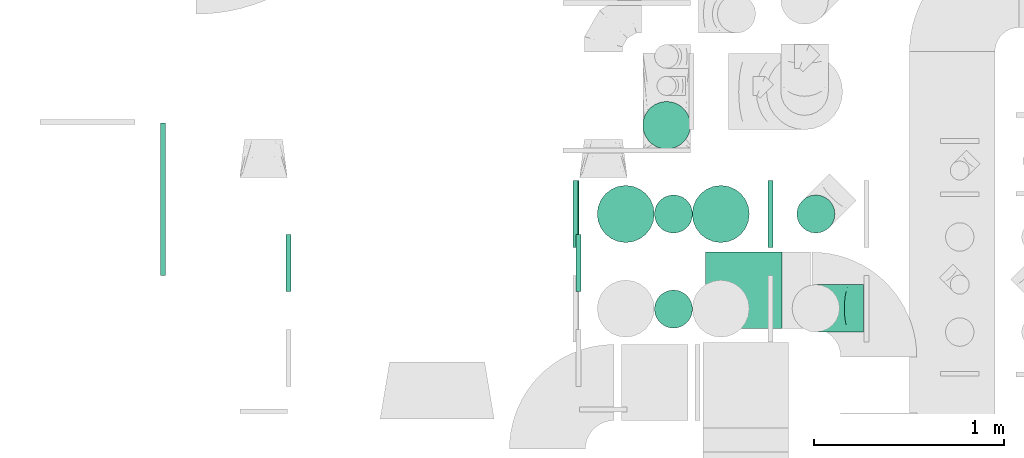
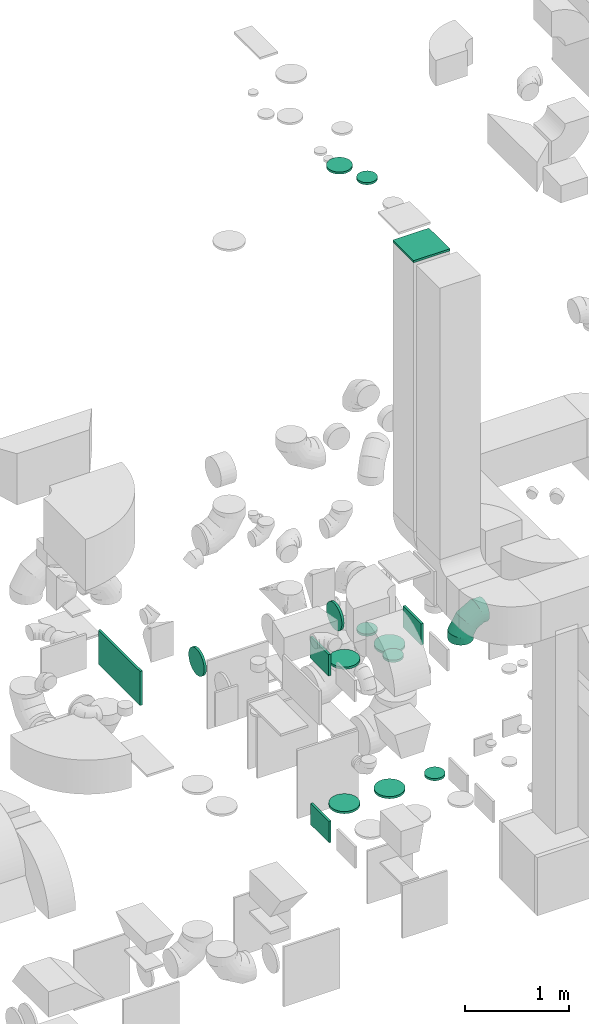
# One storey, part 24 of 59: 17 flow fittings.
"""IFC2X3 building model written with IfcOpenShell, lengths in millimetres."""

import ifcopenshell
import ifcopenshell.guid

model = None  # the IFC model being written
_history = None  # IfcOwnerHistory: only IFC2X3 demands one
_inside = {}  # id of a spatial element -> (the spatial element, [elements in it])
_under = {}  # id of a project, library or spatial element -> (it, [spatial elements below it])
_declared = {}  # id of a project -> (the project, [libraries it declares])
_typed = {}  # id of a type object -> (the type object, [elements of that type])
_made_of = {}  # id of a material, layer set ... -> (it, [elements and type objects made of it])


def new_model(schema):
    """Start an empty IFC model of exactly this schema.

    Asked for "IFC4X3", IfcOpenShell would pick the latest addendum, in which some entities
    have other attributes; the version numbers below select the first issue.
    IFC2X3 requires an IfcOwnerHistory on every rooted entity: one is made here for all.
    """
    global model, _history
    if schema == "IFC4X3":
        model = ifcopenshell.file(schema_version=(4, 3, 0, 0))
    else:
        model = ifcopenshell.file(schema=schema)
    _inside.clear()
    _under.clear()
    _declared.clear()
    _typed.clear()
    _made_of.clear()
    _history = None
    if model.schema == "IFC2X3":
        org = make("IfcOrganization", Name="unknown")
        user = make(
            "IfcPersonAndOrganization",
            ThePerson=make("IfcPerson", FamilyName="unknown"),
            TheOrganization=org,
        )
        app = make(
            "IfcApplication",
            ApplicationDeveloper=org,
            Version="unknown",
            ApplicationFullName="unknown",
            ApplicationIdentifier="unknown",
        )
        _history = make(
            "IfcOwnerHistory",
            OwningUser=user,
            OwningApplication=app,
            ChangeAction="ADDED",
            CreationDate=0,
        )
    return model


def make(cls, **values):
    """One entity of the class cls with the attributes given. An attribute that is None is left unset."""
    return model.create_entity(
        cls, **{name: value for name, value in values.items() if value is not None}
    )


def entity(cls, *values):
    """Any entity or typed value of the class cls, its attributes in the order of the schema. None: left unset."""
    e = model.create_entity(cls)
    for i, value in enumerate(values):
        if value is not None:
            e[i] = value
    return e


def rooted(cls, **values):
    """An entity with a GlobalId (a new one), such as an element, a storey or a relation."""
    return make(cls, GlobalId=ifcopenshell.guid.new(), OwnerHistory=_history, **values)


def si_unit(unit_type, name, prefix=None):
    """IfcSIUnit, for example si_unit("LENGTHUNIT", "METRE", prefix="MILLI")."""
    return make("IfcSIUnit", UnitType=unit_type, Prefix=prefix, Name=name)


def converted_unit(unit_type, name, factor, base, dimensions=None, offset=None):
    """IfcConversionBasedUnit, such as the inch: factor (a typed value) times the base unit."""
    return make(
        "IfcConversionBasedUnit"
        if offset is None
        else "IfcConversionBasedUnitWithOffset",
        ConversionOffset=offset,
        Dimensions=None
        if dimensions is None
        else entity("IfcDimensionalExponents", *dimensions),
        UnitType=unit_type,
        Name=name,
        ConversionFactor=make(
            "IfcMeasureWithUnit", ValueComponent=factor, UnitComponent=base
        ),
    )


def derived_unit(unit_type, elements):
    """IfcDerivedUnit: a product of units, each with its exponent."""
    return make(
        "IfcDerivedUnit",
        Elements=[
            make("IfcDerivedUnitElement", Unit=unit, Exponent=power)
            for unit, power in elements
        ],
        UnitType=unit_type,
    )


def assignment(units):
    """IfcUnitAssignment: the units of a project."""
    return None if units is None else make("IfcUnitAssignment", Units=units)


def point(xyz):
    """IfcCartesianPoint."""
    return None if xyz is None else make("IfcCartesianPoint", Coordinates=xyz)


def direction(xyz):
    """IfcDirection."""
    return None if xyz is None else make("IfcDirection", DirectionRatios=xyz)


def frame(location, z_axis=None, x_axis=None):
    """IfcAxis2Placement3D, a coordinate frame: its origin and axes. An axis left out is left unset."""
    return make(
        "IfcAxis2Placement3D",
        Location=point(location),
        Axis=direction(z_axis),
        RefDirection=direction(x_axis),
    )


def frame_2d(location, x_axis=None):
    """IfcAxis2Placement2D, a coordinate frame in the plane: its origin and x axis."""
    return make(
        "IfcAxis2Placement2D", Location=point(location), RefDirection=direction(x_axis)
    )


def origin():
    """The frame at (0, 0, 0) with its axes left unset."""
    return frame((0.0, 0.0, 0.0))


def origin_2d_with_axis():
    """The frame at (0, 0) in the plane with the x axis (1, 0) written out."""
    return frame_2d((0.0, 0.0), x_axis=(1.0, 0.0))


def place(relative_to, where):
    """IfcLocalPlacement: puts the frame where relative to a parent placement (None: the world)."""
    return make(
        "IfcLocalPlacement", PlacementRelTo=relative_to, RelativePlacement=where
    )


def context(
    kind, dimensions, precision=None, world=None, true_north=None, identifier=None
):
    """IfcGeometricRepresentationContext, for example the 3D "Model" context."""
    return make(
        "IfcGeometricRepresentationContext",
        ContextIdentifier=identifier,
        ContextType=kind,
        CoordinateSpaceDimension=dimensions,
        Precision=precision,
        WorldCoordinateSystem=world,
        TrueNorth=true_north,
    )


def subcontext(parent, identifier, kind, view, scale=None):
    """IfcGeometricRepresentationSubContext, for example "Body" below "Model"."""
    return make(
        "IfcGeometricRepresentationSubContext",
        ContextIdentifier=identifier,
        ContextType=kind,
        ParentContext=parent,
        TargetScale=scale,
        TargetView=view,
    )


def project(units=None, contexts=None):
    """IfcProject with its units and contexts."""
    return rooted(
        "IfcProject",
        Name="project",
        RepresentationContexts=contexts,
        UnitsInContext=assignment(units),
    )


def spatial(cls, under=None, at=None, **own):
    """A site, building, storey or space (cls), placed at a placement, below another one or the project."""
    s = rooted(cls, ObjectPlacement=at, **own)
    if under is not None:
        _under.setdefault(under.id(), (under, []))[1].append(s)
    return s


def profile(cls, at=None, kind="AREA", **sizes):
    """A parametric profile (cls). Its sizes go by their IFC names, for example OverallWidth=200.0."""
    return make(cls, ProfileType=kind, Position=at, **sizes)


def rectangle(**sizes):
    """IfcRectangleProfileDef."""
    return profile("IfcRectangleProfileDef", **sizes)


def circle(**sizes):
    """IfcCircleProfileDef."""
    return profile("IfcCircleProfileDef", **sizes)


def extrude(swept, where, along, depth):
    """IfcExtrudedAreaSolid: the profile swept, set in the frame where, extruded along a direction by depth."""
    return make(
        "IfcExtrudedAreaSolid",
        SweptArea=swept,
        Position=where,
        ExtrudedDirection=direction(along),
        Depth=depth,
    )


def faces_of(points, faces, orient=None, outer=None):
    """IfcFace entities. A face is a list of loops; a loop is a list of indices into points, from 0.

    orient and outer hold one flag for each loop. By default every Orientation is true, the
    first loop of a face is its IfcFaceOuterBound and the others are IfcFaceBound.
    """
    made = []
    for i, loops in enumerate(faces):
        bounds = []
        for j, loop in enumerate(loops):
            is_outer = j == 0 if outer is None else outer[i][j]
            bounds.append(
                make(
                    "IfcFaceOuterBound" if is_outer else "IfcFaceBound",
                    Bound=make("IfcPolyLoop", Polygon=[points[k] for k in loop]),
                    Orientation=True if orient is None else orient[i][j],
                )
            )
        made.append(make("IfcFace", Bounds=bounds))
    return made


def faceted_brep(points, faces, orient=None, outer=None, voids=None):
    """IfcFacetedBrep: a solid bounded by flat faces; with voids (closed shells), ...WithVoids."""
    shared = [point(p) for p in points]
    hull = make("IfcClosedShell", CfsFaces=faces_of(shared, faces, orient, outer))
    if voids is None:
        return make("IfcFacetedBrep", Outer=hull)
    return make(
        "IfcFacetedBrepWithVoids",
        Outer=hull,
        Voids=[
            make(cls, CfsFaces=faces_of(shared, fs, o, b)) for cls, fs, o, b in voids
        ],
    )


def shape(context_of_items, identifier, shape_type, items):
    """IfcShapeRepresentation: the items that make up one representation, for example the "Body"."""
    return make(
        "IfcShapeRepresentation",
        ContextOfItems=context_of_items,
        RepresentationIdentifier=identifier,
        RepresentationType=shape_type,
        Items=items,
    )


def source(mapping_origin, context_of_items, identifier, shape_type, items):
    """IfcRepresentationMap: a shape defined once, which mapped items show again and again."""
    return make(
        "IfcRepresentationMap",
        MappingOrigin=mapping_origin,
        MappedRepresentation=shape(context_of_items, identifier, shape_type, items),
    )


def transform(
    local_origin,
    x_axis=None,
    y_axis=None,
    z_axis=None,
    scale=None,
    scale2=None,
    scale3=None,
    uniform=True,
):
    """IfcCartesianTransformationOperator3D, or its non-uniform kind. x_axis, y_axis, z_axis: its Axis1, 2, 3."""
    if uniform:
        return make(
            "IfcCartesianTransformationOperator3D",
            Axis1=direction(x_axis),
            Axis2=direction(y_axis),
            LocalOrigin=point(local_origin),
            Scale=scale,
            Axis3=direction(z_axis),
        )
    return make(
        "IfcCartesianTransformationOperator3DnonUniform",
        Axis1=direction(x_axis),
        Axis2=direction(y_axis),
        LocalOrigin=point(local_origin),
        Scale=scale,
        Axis3=direction(z_axis),
        Scale2=scale2,
        Scale3=scale3,
    )


def mapped(mapping_source, mapping_target):
    """IfcMappedItem: shows the shape of a source again, moved by a transform."""
    return make(
        "IfcMappedItem", MappingSource=mapping_source, MappingTarget=mapping_target
    )


def material(Name=None, Category=None):
    """IfcMaterial."""
    return make("IfcMaterial", Name=Name, Category=Category)


def made_of(thing, what):
    """Note that an element or type object is made of a material, layer set ...; save() writes the relation."""
    if what is not None:
        _made_of.setdefault(what.id(), (what, []))[1].append(thing)
    return thing


def type_object(cls, material=None, **own):
    """A type object (cls), such as IfcWallType, which elements share."""
    return made_of(rooted(cls, **own), material)


def type_shapes(of_type, sources):
    """Give a type object the sources (RepresentationMaps) that its elements show as mapped items."""
    of_type.RepresentationMaps = sources


def element(
    cls,
    number,
    at=None,
    inside=None,
    cuts=None,
    type_object=None,
    material=None,
    context=None,
    identifier="Body",
    shape_type=None,
    held_by="IfcProductDefinitionShape",
    body=None,
    shapes=None,
    **own,
):
    """One element of the class cls, such as IfcWall. Its Tag is "e" and its number.

    at: its placement. inside: the storey or other place that contains it. cuts: it is an
    opening in that element (IfcRelVoidsElement). A single representation is given by context,
    identifier, shape_type and body (its items); several are given by shapes. held_by: the class
    of the entity that holds the representations. save() writes the other relations.
    """
    e = rooted(cls, Tag="e%d" % number, ObjectPlacement=at, **own)
    if body is not None:
        shapes = [shape(context, identifier, shape_type, body)]
    if shapes is not None:
        e.Representation = make(held_by, Representations=shapes)
    if inside is not None:
        _inside.setdefault(inside.id(), (inside, []))[1].append(e)
    if cuts is not None:
        rooted(
            "IfcRelVoidsElement", RelatingBuildingElement=cuts, RelatedOpeningElement=e
        )
    if type_object is not None:
        _typed.setdefault(type_object.id(), (type_object, []))[1].append(e)
    return made_of(e, material)


def aggregate(whole, parts):
    """IfcRelAggregates: a whole, such as a stair, and the parts it consists of."""
    return rooted("IfcRelAggregates", RelatingObject=whole, RelatedObjects=parts)


def save(model, path):
    """Write the relations noted so far, then the file.

    IfcRelAggregates (storeys below a building ...), IfcRelContainedInSpatialStructure (elements
    in a storey), IfcRelDefinesByType, IfcRelAssociatesMaterial and IfcRelDeclares: one each for
    every whole, place, type object, material and project.
    """
    for whole, parts in _under.values():
        aggregate(whole, parts)
    for where, things in _inside.values():
        rooted(
            "IfcRelContainedInSpatialStructure",
            RelatedElements=things,
            RelatingStructure=where,
        )
    for kind, things in _typed.values():
        rooted("IfcRelDefinesByType", RelatedObjects=things, RelatingType=kind)
    for what, things in _made_of.values():
        rooted("IfcRelAssociatesMaterial", RelatedObjects=things, RelatingMaterial=what)
    for by, libraries in _declared.values():
        rooted("IfcRelDeclares", RelatingContext=by, RelatedDefinitions=libraries)
    model.write(path)


model = new_model("IFC2X3")

# Units and contexts
model_context = context("Model", 3, precision=0.01, world=origin(), true_north=direction((6.12303176911189e-17, 1.0)))
body_context = subcontext(model_context, "Body", "Model", "MODEL_VIEW")
ifc_project = project(units=[si_unit("LENGTHUNIT", "METRE", prefix="MILLI"), si_unit("AREAUNIT", "SQUARE_METRE"), si_unit("VOLUMEUNIT", "CUBIC_METRE"), converted_unit("PLANEANGLEUNIT", "DEGREE", entity("IfcRatioMeasure", 0.0174532925199433), si_unit("PLANEANGLEUNIT", "RADIAN"), dimensions=[0, 0, 0, 0, 0, 0, 0]), si_unit("MASSUNIT", "GRAM", prefix="KILO"), derived_unit("MASSDENSITYUNIT", [(si_unit("MASSUNIT", "GRAM", prefix="KILO"), 1), (si_unit("LENGTHUNIT", "METRE"), -3)]), derived_unit("MOMENTOFINERTIAUNIT", [(si_unit("LENGTHUNIT", "METRE"), 4)]), si_unit("TIMEUNIT", "SECOND"), si_unit("FREQUENCYUNIT", "HERTZ"), si_unit("THERMODYNAMICTEMPERATUREUNIT", "DEGREE_CELSIUS"), derived_unit("THERMALTRANSMITTANCEUNIT", [(si_unit("MASSUNIT", "GRAM", prefix="KILO"), 1), (si_unit("THERMODYNAMICTEMPERATUREUNIT", "KELVIN"), -1), (si_unit("TIMEUNIT", "SECOND"), -3)]), derived_unit("VOLUMETRICFLOWRATEUNIT", [(si_unit("LENGTHUNIT", "METRE"), 3), (si_unit("TIMEUNIT", "SECOND"), -1)]), derived_unit("MASSFLOWRATEUNIT", [(si_unit("MASSUNIT", "GRAM", prefix="KILO"), 1), (si_unit("TIMEUNIT", "SECOND"), -1)]), derived_unit("ROTATIONALFREQUENCYUNIT", [(si_unit("TIMEUNIT", "SECOND"), -1)]), si_unit("ELECTRICCURRENTUNIT", "AMPERE"), si_unit("ELECTRICVOLTAGEUNIT", "VOLT"), si_unit("POWERUNIT", "WATT"), si_unit("FORCEUNIT", "NEWTON", prefix="KILO"), si_unit("ILLUMINANCEUNIT", "LUX"), si_unit("LUMINOUSFLUXUNIT", "LUMEN"), si_unit("LUMINOUSINTENSITYUNIT", "CANDELA"), derived_unit("USERDEFINED", [(si_unit("MASSUNIT", "GRAM", prefix="KILO"), -1), (si_unit("LENGTHUNIT", "METRE"), -2), (si_unit("TIMEUNIT", "SECOND"), 3), (si_unit("LUMINOUSFLUXUNIT", "LUMEN"), 1)]), derived_unit("LINEARVELOCITYUNIT", [(si_unit("LENGTHUNIT", "METRE"), 1), (si_unit("TIMEUNIT", "SECOND"), -1)]), si_unit("PRESSUREUNIT", "PASCAL"), derived_unit("USERDEFINED", [(si_unit("LENGTHUNIT", "METRE"), -2), (si_unit("MASSUNIT", "GRAM", prefix="KILO"), 1), (si_unit("TIMEUNIT", "SECOND"), -2)]), derived_unit("LINEARFORCEUNIT", [(si_unit("MASSUNIT", "GRAM", prefix="KILO"), 1), (si_unit("LENGTHUNIT", "METRE"), 1), (si_unit("TIMEUNIT", "SECOND"), -2), (si_unit("LENGTHUNIT", "METRE"), -1)]), derived_unit("PLANARFORCEUNIT", [(si_unit("MASSUNIT", "GRAM", prefix="KILO"), 1), (si_unit("LENGTHUNIT", "METRE"), 1), (si_unit("TIMEUNIT", "SECOND"), -2), (si_unit("LENGTHUNIT", "METRE"), -2)])], contexts=[model_context])

# Site, building, storey
site_placement = place(None, origin())
site = spatial("IfcSite", under=ifc_project, at=site_placement, CompositionType="ELEMENT")
building_placement = place(site_placement, origin())
building = spatial("IfcBuilding", under=site, at=building_placement, CompositionType="ELEMENT")
storey_placement = place(building_placement, frame((0.0, 0.0, 28200.0)))
storey = spatial("IfcBuildingStorey", under=building, at=storey_placement, CompositionType="ELEMENT", Elevation=28200.0)

# Flow fittings
ifc_material = material()
duct_fitting_type_1 = type_object("IfcDuctFittingType", PredefinedType="NOTDEFINED", material=ifc_material)
shared_shape_1 = source(origin(), body_context, "Body", "SweptSolid", [
    extrude(circle(Radius=99.9999999999994, at=origin_2d_with_axis()), frame((0.0, 0.0, 0.0), z_axis=(1.0, 0.0, 0.0), x_axis=(0.0, 1.0, 0.0)), (0.0, 0.0, 1.0), 25.0000000000018),
])
type_shapes(duct_fitting_type_1, [shared_shape_1])
flow_fitting_1_placement = place(storey_placement, frame((55631.15, 10234.06, 7677.46), z_axis=(-1.0, 0.0, 0.0), x_axis=(0.0, 0.0, 1.0)))
element("IfcFlowFitting", 1, at=flow_fitting_1_placement, inside=storey, type_object=duct_fitting_type_1, material=ifc_material, context=body_context, shape_type="MappedRepresentation", body=[
    mapped(shared_shape_1, transform((0.0, 0.0, 0.0), scale=1.0)),
])
duct_fitting_type_2 = type_object("IfcDuctFittingType", PredefinedType="NOTDEFINED", material=ifc_material)
shared_shape_2 = source(origin(), body_context, "Body", "SweptSolid", [
    extrude(rectangle(XDim=24.9999999999999, YDim=400.0, at=origin_2d_with_axis()), frame((12.5, 0.0, -200.0)), (0.0, 0.0, 1.0), 400.0),
])
type_shapes(duct_fitting_type_2, [shared_shape_2])
flow_fitting_2_placement = place(storey_placement, frame((56000.5, 9833.0, 7000.0), z_axis=(1.0, 0.0, 0.0), x_axis=(0.0, 0.0, 1.0)))
element("IfcFlowFitting", 2, at=flow_fitting_2_placement, inside=storey, type_object=duct_fitting_type_2, material=ifc_material, context=body_context, shape_type="MappedRepresentation", body=[
    mapped(shared_shape_2, transform((0.0, 0.0, 0.0), scale=1.0)),
])
duct_fitting_type_3 = type_object("IfcDuctFittingType", PredefinedType="NOTDEFINED", material=ifc_material)
shared_shape_3 = source(origin(), body_context, "Body", "SweptSolid", [
    extrude(circle(Radius=124.999999999999, at=origin_2d_with_axis()), frame((0.0, 0.0, 0.0), z_axis=(1.0, 0.0, 0.0), x_axis=(0.0, 1.0, 0.0)), (0.0, 0.0, 1.0), 25.0000000000018),
])
type_shapes(duct_fitting_type_3, [shared_shape_3])
flow_fitting_3_placement = place(storey_placement, frame((55595.02, 10700.6, 7548.56), z_axis=(0.0, 1.0, 0.0), x_axis=(0.0, 0.0, 1.0)))
element("IfcFlowFitting", 3, at=flow_fitting_3_placement, inside=storey, type_object=duct_fitting_type_3, material=ifc_material, context=body_context, shape_type="MappedRepresentation", body=[
    mapped(shared_shape_3, transform((0.0, 0.0, 0.0), scale=1.0)),
])
duct_fitting_type_4 = type_object("IfcDuctFittingType", PredefinedType="NOTDEFINED", material=ifc_material)
shared_shape_4 = source(origin(), body_context, "Body", "SweptSolid", [
    extrude(rectangle(XDim=24.9999999999999, YDim=350.0, at=origin_2d_with_axis()), frame((12.5, 0.0, -125.0)), (0.0, 0.0, 1.0), 250.0),
])
type_shapes(duct_fitting_type_4, [shared_shape_4])
for number, where, z_axis, x_axis in (
    (4, (55128.85, 10234.06, 2277.46), (0.0, 0.0, 1.0), (-1.0, 0.0, 0.0)),
    (5, (55133.85, 10234.06, 325.0), (0.0, 0.0, 1.0), (-1.0, 0.0, 0.0)),
):
    element("IfcFlowFitting", number, at=place(storey_placement, frame(where, z_axis=z_axis, x_axis=x_axis)), inside=storey, type_object=duct_fitting_type_4, material=ifc_material, context=body_context, shape_type="MappedRepresentation", body=[
        mapped(shared_shape_4, transform((0.0, 0.0, 0.0), scale=1.0)),
    ])
flow_fitting_4_placement = place(storey_placement, frame((56128.85, 10234.06, 2277.46)))
element("IfcFlowFitting", 6, at=flow_fitting_4_placement, inside=storey, type_object=duct_fitting_type_4, material=ifc_material, context=body_context, shape_type="MappedRepresentation", body=[
    mapped(shared_shape_4, transform((0.0, 0.0, 0.0), scale=1.0)),
])
duct_fitting_type_5 = type_object("IfcDuctFittingType", PredefinedType="NOTDEFINED", material=ifc_material)
shared_shape_5 = source(origin(), body_context, "Body", "SweptSolid", [
    extrude(rectangle(XDim=24.9999999999999, YDim=800.0, at=origin_2d_with_axis()), frame((12.5, 0.0, -200.0)), (0.0, 0.0, 1.0), 400.0),
])
type_shapes(duct_fitting_type_5, [shared_shape_5])
flow_fitting_5_placement = place(storey_placement, frame((52933.61, 10311.5, 2855.02)))
element("IfcFlowFitting", 7, at=flow_fitting_5_placement, inside=storey, type_object=duct_fitting_type_5, material=ifc_material, context=body_context, shape_type="MappedRepresentation", body=[
    mapped(shared_shape_5, transform((0.0, 0.0, 0.0), scale=1.0)),
])
duct_fitting_type_6 = type_object("IfcDuctFittingType", PredefinedType="NOTDEFINED", material=ifc_material)
shared_shape_6 = source(origin(), body_context, "Body", "Brep", [
    faceted_brep([(-250.0, 0.0, -125.0), (-250.0, -32.35, -120.74), (-250.0, -62.5, -108.25), (-250.0, -88.39, -88.39), (-250.0, -108.25, -62.5), (-250.0, -120.74, -32.35), (-250.0, -125.0, 0.0), (-250.0, -120.74, 32.35), (-250.0, -108.25, 62.5), (-250.0, -88.39, 88.39), (-250.0, -62.5, 108.25), (-250.0, -32.35, 120.74), (-250.0, 0.0, 125.0), (-250.0, 32.35, 120.74), (-250.0, 62.5, 108.25), (-250.0, 88.39, 88.39), (-250.0, 108.25, 62.5), (-250.0, 120.74, 32.35), (-250.0, 125.0, 0.0), (-250.0, 120.74, -32.35), (-250.0, 108.25, -62.5), (-250.0, 88.39, -88.39), (-250.0, 62.5, -108.25), (-250.0, 32.35, -120.74), (-191.68, 32.35, 120.74), (-199.76, 62.5, 108.25), (-183.01, 0.0, 125.0), (-206.7, 88.39, 88.39), (-215.37, 120.74, 32.35), (-216.51, 125.0, 0.0), (-212.02, 108.25, 62.5), (-212.02, 108.25, -62.5), (-206.7, 88.39, -88.39), (-215.37, 120.74, -32.35), (-191.68, 32.35, -120.74), (-183.01, 0.0, -125.0), (-199.76, 62.5, -108.25), (-174.34, -32.35, -120.74), (-166.27, -62.5, -108.25), (-159.33, -88.39, -88.39), (-154.01, -108.25, -62.5), (-150.66, -120.74, -32.35), (-149.52, -125.0, 0.0), (-150.66, -120.74, 32.35), (-154.01, -108.25, 62.5), (-159.33, -88.39, 88.39), (-166.27, -62.5, 108.25), (-174.34, -32.35, 120.74), (-90.67, 90.67, 120.74), (-112.74, 112.74, 108.25), (-66.99, 66.99, 125.0), (-131.69, 131.69, 88.39), (-146.23, 146.23, 62.5), (-155.38, 155.38, 32.35), (-158.49, 158.49, 0.0), (-155.38, 155.38, -32.35), (-146.23, 146.23, -62.5), (-131.69, 131.69, -88.39), (-90.67, 90.67, -120.74), (-66.99, 66.99, -125.0), (-112.74, 112.74, -108.25), (-43.3, 43.3, -120.74), (-21.23, 21.23, -108.25), (-2.28, 2.28, -88.39), (12.26, -12.26, -62.5), (21.4, -21.4, -32.35), (24.52, -24.52, 0.0), (21.4, -21.4, 32.35), (12.26, -12.26, 62.5), (-2.28, 2.28, 88.39), (-21.23, 21.23, 108.25), (-43.3, 43.3, 120.74), (-32.35, 191.68, 120.74), (-62.5, 199.76, 108.25), (0.0, 183.01, 125.0), (-88.39, 206.7, 88.39), (-108.25, 212.02, 62.5), (-120.74, 215.37, 32.35), (-125.0, 216.51, 0.0), (-120.74, 215.37, -32.35), (-108.25, 212.02, -62.5), (-88.39, 206.7, -88.39), (-32.35, 191.68, -120.74), (0.0, 183.01, -125.0), (-62.5, 199.76, -108.25), (32.35, 174.34, -120.74), (62.5, 166.27, -108.25), (88.39, 159.33, -88.39), (108.25, 154.01, -62.5), (120.74, 150.66, -32.35), (125.0, 149.52, 0.0), (120.74, 150.66, 32.35), (108.25, 154.01, 62.5), (88.39, 159.33, 88.39), (62.5, 166.27, 108.25), (32.35, 174.34, 120.74), (-32.35, 250.0, -120.74), (-62.5, 250.0, -108.25), (-88.39, 250.0, -88.39), (-108.25, 250.0, -62.5), (-120.74, 250.0, -32.35), (-125.0, 250.0, 0.0), (-120.74, 250.0, 32.35), (-108.25, 250.0, 62.5), (-88.39, 250.0, 88.39), (-62.5, 250.0, 108.25), (-32.35, 250.0, 120.74), (0.0, 250.0, 125.0), (32.35, 250.0, 120.74), (62.5, 250.0, 108.25), (88.39, 250.0, 88.39), (108.25, 250.0, 62.5), (120.74, 250.0, 32.35), (125.0, 250.0, 0.0), (120.74, 250.0, -32.35), (108.25, 250.0, -62.5), (88.39, 250.0, -88.39), (62.5, 250.0, -108.25), (32.35, 250.0, -120.74), (0.0, 250.0, -125.0)], [[[0, 1, 2, 3, 4, 5, 6, 7, 8, 9, 10, 11, 12, 13, 14, 15, 16, 17, 18, 19, 20, 21, 22, 23]], [[24, 25, 14, 13]], [[26, 24, 13, 12]], [[14, 25, 27, 15]], [[28, 29, 18, 17]], [[30, 28, 17, 16]], [[15, 27, 30, 16]], [[20, 31, 32, 21]], [[33, 31, 20, 19]], [[18, 29, 33, 19]], [[34, 35, 0, 23]], [[36, 34, 23, 22]], [[21, 32, 36, 22]], [[1, 0, 35, 37]], [[2, 1, 37, 38]], [[38, 39, 3, 2]], [[5, 4, 40, 41]], [[6, 5, 41, 42]], [[39, 40, 4, 3]], [[6, 42, 43, 7]], [[7, 43, 44, 8]], [[8, 44, 45, 9]], [[9, 45, 46, 10]], [[10, 46, 47, 11]], [[26, 12, 11, 47]], [[48, 49, 25, 24]], [[50, 48, 24, 26]], [[27, 25, 49, 51]], [[52, 53, 28, 30]], [[51, 52, 30, 27]], [[29, 28, 53, 54]], [[55, 56, 31, 33]], [[54, 55, 33, 29]], [[32, 31, 56, 57]], [[58, 59, 35, 34]], [[60, 58, 34, 36]], [[57, 60, 36, 32]], [[37, 35, 59, 61]], [[38, 37, 61, 62]], [[39, 38, 62, 63]], [[41, 40, 64, 65]], [[42, 41, 65, 66]], [[63, 64, 40, 39]], [[43, 42, 66, 67]], [[44, 43, 67, 68]], [[68, 69, 45, 44]], [[46, 45, 69, 70]], [[47, 46, 70, 71]], [[26, 47, 71, 50]], [[72, 73, 49, 48]], [[74, 72, 48, 50]], [[51, 49, 73, 75]], [[76, 77, 53, 52]], [[75, 76, 52, 51]], [[54, 53, 77, 78]], [[79, 80, 56, 55]], [[78, 79, 55, 54]], [[57, 56, 80, 81]], [[82, 83, 59, 58]], [[84, 82, 58, 60]], [[81, 84, 60, 57]], [[61, 59, 83, 85]], [[62, 61, 85, 86]], [[63, 62, 86, 87]], [[65, 64, 88, 89]], [[66, 65, 89, 90]], [[87, 88, 64, 63]], [[67, 66, 90, 91]], [[68, 67, 91, 92]], [[92, 93, 69, 68]], [[70, 69, 93, 94]], [[71, 70, 94, 95]], [[50, 71, 95, 74]], [[96, 97, 98, 99, 100, 101, 102, 103, 104, 105, 106, 107, 108, 109, 110, 111, 112, 113, 114, 115, 116, 117, 118, 119]], [[72, 74, 107, 106]], [[73, 72, 106, 105]], [[75, 73, 105, 104]], [[77, 76, 103, 102]], [[78, 77, 102, 101]], [[75, 104, 103, 76]], [[78, 101, 100, 79]], [[79, 100, 99, 80]], [[80, 99, 98, 81]], [[84, 97, 96, 82]], [[82, 96, 119, 83]], [[84, 81, 98, 97]], [[83, 119, 118, 85]], [[85, 118, 117, 86]], [[116, 87, 86, 117]], [[88, 115, 114, 89]], [[89, 114, 113, 90]], [[115, 88, 87, 116]], [[91, 90, 113, 112]], [[92, 91, 112, 111]], [[111, 110, 93, 92]], [[95, 94, 109, 108]], [[74, 95, 108, 107]], [[110, 109, 94, 93]]]),
])
type_shapes(duct_fitting_type_6, [shared_shape_6])
flow_fitting_6_placement = place(storey_placement, frame((56380.0, 9738.12, 2597.2), z_axis=(0.0, 1.0, 0.0), x_axis=(0.0, 0.0, 1.0)))
element("IfcFlowFitting", 8, at=flow_fitting_6_placement, inside=storey, type_object=duct_fitting_type_6, material=ifc_material, context=body_context, shape_type="MappedRepresentation", body=[
    mapped(shared_shape_6, transform((0.0, 0.0, 0.0), scale=1.0)),
])
duct_fitting_type_7 = type_object("IfcDuctFittingType", PredefinedType="NOTDEFINED", material=ifc_material)
shared_shape_7 = source(origin(), body_context, "Body", "Brep", [
    faceted_brep([(20.0, 25.88, -96.59), (20.0, 50.0, -86.6), (20.0, 70.71, -70.71), (20.0, 86.6, -50.0), (20.0, 96.59, -25.88), (20.0, 100.0, 0.0), (20.0, 96.59, 25.88), (20.0, 86.6, 50.0), (20.0, 70.71, 70.71), (20.0, 50.0, 86.6), (20.0, 25.88, 96.59), (20.0, 0.0, 100.0), (20.0, -25.88, 96.59), (20.0, -50.0, 86.6), (20.0, -70.71, 70.71), (20.0, -86.6, 50.0), (20.0, -96.59, 25.88), (20.0, -100.0, 0.0), (20.0, -96.59, -25.88), (20.0, -86.6, -50.0), (20.0, -70.71, -70.71), (20.0, -50.0, -86.6), (20.0, -25.88, -96.59), (20.0, 0.0, -100.0), (0.0, 0.0, 100.0), (0.0, 25.88, 96.59), (-6.1, 25.88, 96.59), (-6.1, 0.0, 100.0), (0.0, 50.0, 86.6), (-6.1, 50.0, 86.6), (0.0, 70.71, 70.71), (-6.1, 70.71, 70.71), (0.0, 86.6, 50.0), (0.0, 96.59, 25.88), (-6.1, 96.59, 25.88), (-6.1, 86.6, 50.0), (0.0, 100.0, 0.0), (-6.1, 100.0, 0.0), (0.0, 96.59, -25.88), (-6.1, 96.59, -25.88), (0.0, 86.6, -50.0), (-6.1, 86.6, -50.0), (0.0, 70.71, -70.71), (-6.1, 70.71, -70.71), (0.0, 50.0, -86.6), (0.0, 25.88, -96.59), (-6.1, 25.88, -96.59), (-6.1, 50.0, -86.6), (0.0, 0.0, -100.0), (-6.1, 0.0, -100.0), (0.0, -25.88, -96.59), (-6.1, -25.88, -96.59), (0.0, -50.0, -86.6), (-6.1, -50.0, -86.6), (0.0, -70.71, -70.71), (-6.1, -70.71, -70.71), (0.0, -86.6, -50.0), (0.0, -96.59, -25.88), (-6.1, -96.59, -25.88), (-6.1, -86.6, -50.0), (0.0, -100.0, 0.0), (-6.1, -100.0, 0.0), (0.0, -96.59, 25.88), (-6.1, -96.59, 25.88), (0.0, -86.6, 50.0), (-6.1, -86.6, 50.0), (0.0, -70.71, 70.71), (-6.1, -70.71, 70.71), (0.0, -50.0, 86.6), (0.0, -25.88, 96.59), (-6.1, -25.88, 96.59), (-6.1, -50.0, 86.6)], [[[0, 1, 2, 3, 4, 5, 6, 7, 8, 9, 10, 11, 12, 13, 14, 15, 16, 17, 18, 19, 20, 21, 22, 23]], [[24, 11, 10, 25, 26, 27]], [[25, 10, 9, 28, 29, 26]], [[28, 9, 8, 30, 31, 29]], [[32, 7, 6, 33, 34, 35]], [[33, 6, 5, 36, 37, 34]], [[30, 8, 7, 32, 35, 31]], [[36, 5, 4, 38, 39, 37]], [[38, 4, 3, 40, 41, 39]], [[40, 3, 2, 42, 43, 41]], [[44, 1, 0, 45, 46, 47]], [[45, 0, 23, 48, 49, 46]], [[42, 2, 1, 44, 47, 43]], [[48, 23, 22, 50, 51, 49]], [[50, 22, 21, 52, 53, 51]], [[52, 21, 20, 54, 55, 53]], [[56, 19, 18, 57, 58, 59]], [[57, 18, 17, 60, 61, 58]], [[54, 20, 19, 56, 59, 55]], [[60, 17, 16, 62, 63, 61]], [[62, 16, 15, 64, 65, 63]], [[64, 15, 14, 66, 67, 65]], [[68, 13, 12, 69, 70, 71]], [[69, 12, 11, 24, 27, 70]], [[66, 14, 13, 68, 71, 67]], [[49, 51, 53, 55, 59, 58, 61, 63, 65, 67, 71, 70, 27, 26, 29, 31, 35, 34, 37, 39, 41, 43, 47, 46]]]),
])
type_shapes(duct_fitting_type_7, [shared_shape_7])
flow_fitting_7_placement = place(storey_placement, frame((55631.15, 10234.06, 2402.46), z_axis=(1.0, 0.0, 0.0), x_axis=(0.0, 0.0, 1.0)))
element("IfcFlowFitting", 9, at=flow_fitting_7_placement, inside=storey, type_object=duct_fitting_type_7, material=ifc_material, context=body_context, shape_type="MappedRepresentation", body=[
    mapped(shared_shape_7, transform((0.0, 0.0, 0.0), scale=1.0)),
])
duct_fitting_type_8 = type_object("IfcDuctFittingType", PredefinedType="NOTDEFINED", material=ifc_material)
shared_shape_8 = source(origin(), body_context, "Body", "Brep", [
    faceted_brep([(20.0, 0.0, -100.0), (20.0, 25.88, -96.59), (20.0, 50.0, -86.6), (20.0, 70.71, -70.71), (20.0, 86.6, -50.0), (20.0, 96.59, -25.88), (20.0, 100.0, 0.0), (20.0, 96.59, 25.88), (20.0, 86.6, 50.0), (20.0, 70.71, 70.71), (20.0, 50.0, 86.6), (20.0, 25.88, 96.59), (20.0, 0.0, 100.0), (20.0, -25.88, 96.59), (20.0, -50.0, 86.6), (20.0, -70.71, 70.71), (20.0, -86.6, 50.0), (20.0, -96.59, 25.88), (20.0, -100.0, 0.0), (20.0, -96.59, -25.88), (20.0, -86.6, -50.0), (20.0, -70.71, -70.71), (20.0, -50.0, -86.6), (20.0, -25.88, -96.59), (0.0, 0.0, 100.0), (-6.1, 0.0, 100.0), (-6.1, -25.88, 96.59), (0.0, -25.88, 96.59), (-6.1, -50.0, 86.6), (0.0, -50.0, 86.6), (0.0, -70.71, 70.71), (-6.1, -70.71, 70.71), (0.0, -86.6, 50.0), (-6.1, -86.6, 50.0), (-6.1, -96.59, 25.88), (0.0, -96.59, 25.88), (-6.1, -100.0, 0.0), (0.0, -100.0, 0.0), (-6.1, -96.59, -25.88), (0.0, -96.59, -25.88), (-6.1, -86.6, -50.0), (0.0, -86.6, -50.0), (0.0, -70.71, -70.71), (-6.1, -70.71, -70.71), (0.0, -50.0, -86.6), (-6.1, -50.0, -86.6), (-6.1, -25.88, -96.59), (0.0, -25.88, -96.59), (-6.1, 0.0, -100.0), (0.0, 0.0, -100.0), (-6.1, 25.88, -96.59), (0.0, 25.88, -96.59), (-6.1, 50.0, -86.6), (0.0, 50.0, -86.6), (0.0, 70.71, -70.71), (-6.1, 70.71, -70.71), (0.0, 86.6, -50.0), (-6.1, 86.6, -50.0), (-6.1, 96.59, -25.88), (0.0, 96.59, -25.88), (-6.1, 100.0, 0.0), (0.0, 100.0, 0.0), (-6.1, 96.59, 25.88), (0.0, 96.59, 25.88), (-6.1, 86.6, 50.0), (0.0, 86.6, 50.0), (0.0, 70.71, 70.71), (-6.1, 70.71, 70.71), (0.0, 50.0, 86.6), (-6.1, 50.0, 86.6), (-6.1, 25.88, 96.59), (0.0, 25.88, 96.59)], [[[0, 1, 2, 3, 4, 5, 6, 7, 8, 9, 10, 11, 12, 13, 14, 15, 16, 17, 18, 19, 20, 21, 22, 23]], [[13, 12, 24, 25, 26, 27]], [[14, 13, 27, 26, 28, 29]], [[30, 15, 14, 29, 28, 31]], [[17, 16, 32, 33, 34, 35]], [[18, 17, 35, 34, 36, 37]], [[32, 16, 15, 30, 31, 33]], [[19, 18, 37, 36, 38, 39]], [[20, 19, 39, 38, 40, 41]], [[42, 21, 20, 41, 40, 43]], [[23, 22, 44, 45, 46, 47]], [[0, 23, 47, 46, 48, 49]], [[44, 22, 21, 42, 43, 45]], [[1, 0, 49, 48, 50, 51]], [[2, 1, 51, 50, 52, 53]], [[54, 3, 2, 53, 52, 55]], [[5, 4, 56, 57, 58, 59]], [[6, 5, 59, 58, 60, 61]], [[56, 4, 3, 54, 55, 57]], [[7, 6, 61, 60, 62, 63]], [[8, 7, 63, 62, 64, 65]], [[66, 9, 8, 65, 64, 67]], [[11, 10, 68, 69, 70, 71]], [[12, 11, 71, 70, 25, 24]], [[68, 10, 9, 66, 67, 69]], [[46, 45, 43, 40, 38, 36, 34, 33, 31, 28, 26, 25, 70, 69, 67, 64, 62, 60, 58, 57, 55, 52, 50, 48]]]),
])
type_shapes(duct_fitting_type_8, [shared_shape_8])
for number, where, z_axis, x_axis in (
    (10, (56380.0, 10234.06, 450.0), (-1.0, 0.0, 0.0), (0.0, 0.0, 1.0)),
    (11, (55631.15, 9734.06, 2400.0), (1.0, 0.0, 0.0), (0.0, 0.0, 1.0)),
):
    element("IfcFlowFitting", number, at=place(storey_placement, frame(where, z_axis=z_axis, x_axis=x_axis)), inside=storey, type_object=duct_fitting_type_8, material=ifc_material, context=body_context, shape_type="MappedRepresentation", body=[
        mapped(shared_shape_8, transform((0.0, 0.0, 0.0), scale=1.0)),
    ])
duct_fitting_type_9 = type_object("IfcDuctFittingType", PredefinedType="NOTDEFINED", material=ifc_material)
shared_shape_9 = source(origin(), body_context, "Body", "Brep", [
    faceted_brep([(20.0, 0.0, -150.0), (20.0, 38.82, -144.89), (20.0, 75.0, -129.9), (20.0, 106.07, -106.07), (20.0, 129.9, -75.0), (20.0, 144.89, -38.82), (20.0, 150.0, 0.0), (20.0, 144.89, 38.82), (20.0, 129.9, 75.0), (20.0, 106.07, 106.07), (20.0, 75.0, 129.9), (20.0, 38.82, 144.89), (20.0, 0.0, 150.0), (20.0, -38.82, 144.89), (20.0, -75.0, 129.9), (20.0, -106.07, 106.07), (20.0, -129.9, 75.0), (20.0, -144.89, 38.82), (20.0, -150.0, 0.0), (20.0, -144.89, -38.82), (20.0, -129.9, -75.0), (20.0, -106.07, -106.07), (20.0, -75.0, -129.9), (20.0, -38.82, -144.89), (0.0, 0.0, 150.0), (-6.1, 0.0, 150.0), (-6.1, -38.82, 144.89), (0.0, -38.82, 144.89), (-6.1, -75.0, 129.9), (0.0, -75.0, 129.9), (0.0, -106.07, 106.07), (-6.1, -106.07, 106.07), (0.0, -129.9, 75.0), (-6.1, -129.9, 75.0), (-6.1, -144.89, 38.82), (0.0, -144.89, 38.82), (-6.1, -150.0, 0.0), (0.0, -150.0, 0.0), (-6.1, -144.89, -38.82), (0.0, -144.89, -38.82), (-6.1, -129.9, -75.0), (0.0, -129.9, -75.0), (0.0, -106.07, -106.07), (-6.1, -106.07, -106.07), (0.0, -75.0, -129.9), (-6.1, -75.0, -129.9), (-6.1, -38.82, -144.89), (0.0, -38.82, -144.89), (-6.1, 0.0, -150.0), (0.0, 0.0, -150.0), (-6.1, 38.82, -144.89), (0.0, 38.82, -144.89), (-6.1, 75.0, -129.9), (0.0, 75.0, -129.9), (0.0, 106.07, -106.07), (-6.1, 106.07, -106.07), (0.0, 129.9, -75.0), (-6.1, 129.9, -75.0), (-6.1, 144.89, -38.82), (0.0, 144.89, -38.82), (-6.1, 150.0, 0.0), (0.0, 150.0, 0.0), (-6.1, 144.89, 38.82), (0.0, 144.89, 38.82), (-6.1, 129.9, 75.0), (0.0, 129.9, 75.0), (0.0, 106.07, 106.07), (-6.1, 106.07, 106.07), (0.0, 75.0, 129.9), (-6.1, 75.0, 129.9), (-6.1, 38.82, 144.89), (0.0, 38.82, 144.89)], [[[0, 1, 2, 3, 4, 5, 6, 7, 8, 9, 10, 11, 12, 13, 14, 15, 16, 17, 18, 19, 20, 21, 22, 23]], [[13, 12, 24, 25, 26, 27]], [[14, 13, 27, 26, 28, 29]], [[30, 15, 14, 29, 28, 31]], [[17, 16, 32, 33, 34, 35]], [[18, 17, 35, 34, 36, 37]], [[32, 16, 15, 30, 31, 33]], [[19, 18, 37, 36, 38, 39]], [[20, 19, 39, 38, 40, 41]], [[42, 21, 20, 41, 40, 43]], [[23, 22, 44, 45, 46, 47]], [[0, 23, 47, 46, 48, 49]], [[44, 22, 21, 42, 43, 45]], [[1, 0, 49, 48, 50, 51]], [[2, 1, 51, 50, 52, 53]], [[54, 3, 2, 53, 52, 55]], [[5, 4, 56, 57, 58, 59]], [[6, 5, 59, 58, 60, 61]], [[56, 4, 3, 54, 55, 57]], [[7, 6, 61, 60, 62, 63]], [[8, 7, 63, 62, 64, 65]], [[66, 9, 8, 65, 64, 67]], [[11, 10, 68, 69, 70, 71]], [[12, 11, 71, 70, 25, 24]], [[68, 10, 9, 66, 67, 69]], [[46, 45, 43, 40, 38, 36, 34, 33, 31, 28, 26, 25, 70, 69, 67, 64, 62, 60, 58, 57, 55, 52, 50, 48]]]),
])
type_shapes(duct_fitting_type_9, [shared_shape_9])
for number, where, z_axis, x_axis in (
    (12, (55880.0, 10234.06, 2152.46), (-1.0, 0.0, 0.0), (0.0, 0.0, -1.0)),
    (13, (55880.0, 10234.06, 450.0), (-1.0, 0.0, 0.0), (0.0, 0.0, 1.0)),
    (14, (55380.0, 10234.06, 2152.46), (-1.0, 0.0, 0.0), (0.0, 0.0, -1.0)),
    (15, (55380.0, 10234.06, 450.0), (-1.0, 0.0, 0.0), (0.0, 0.0, 1.0)),
):
    element("IfcFlowFitting", number, at=place(storey_placement, frame(where, z_axis=z_axis, x_axis=x_axis)), inside=storey, type_object=duct_fitting_type_9, material=ifc_material, context=body_context, shape_type="MappedRepresentation", body=[
        mapped(shared_shape_9, transform((0.0, 0.0, 0.0), scale=1.0)),
    ])
duct_fitting_type_10 = type_object("IfcDuctFittingType", PredefinedType="NOTDEFINED", material=ifc_material)
shared_shape_10 = source(origin(), body_context, "Body", "Brep", [
    faceted_brep([(20.0, 38.82, -144.89), (20.0, 75.0, -129.9), (20.0, 106.07, -106.07), (20.0, 129.9, -75.0), (20.0, 144.89, -38.82), (20.0, 150.0, 0.0), (20.0, 144.89, 38.82), (20.0, 129.9, 75.0), (20.0, 106.07, 106.07), (20.0, 75.0, 129.9), (20.0, 38.82, 144.89), (20.0, 0.0, 150.0), (20.0, -38.82, 144.89), (20.0, -75.0, 129.9), (20.0, -106.07, 106.07), (20.0, -129.9, 75.0), (20.0, -144.89, 38.82), (20.0, -150.0, 0.0), (20.0, -144.89, -38.82), (20.0, -129.9, -75.0), (20.0, -106.07, -106.07), (20.0, -75.0, -129.9), (20.0, -38.82, -144.89), (20.0, 0.0, -150.0), (0.0, 0.0, 150.0), (0.0, 38.82, 144.89), (-6.1, 38.82, 144.89), (-6.1, 0.0, 150.0), (0.0, 75.0, 129.9), (-6.1, 75.0, 129.9), (0.0, 106.07, 106.07), (-6.1, 106.07, 106.07), (0.0, 129.9, 75.0), (0.0, 144.89, 38.82), (-6.1, 144.89, 38.82), (-6.1, 129.9, 75.0), (0.0, 150.0, 0.0), (-6.1, 150.0, 0.0), (0.0, 144.89, -38.82), (-6.1, 144.89, -38.82), (0.0, 129.9, -75.0), (-6.1, 129.9, -75.0), (0.0, 106.07, -106.07), (-6.1, 106.07, -106.07), (0.0, 75.0, -129.9), (0.0, 38.82, -144.89), (-6.1, 38.82, -144.89), (-6.1, 75.0, -129.9), (0.0, 0.0, -150.0), (-6.1, 0.0, -150.0), (0.0, -38.82, -144.89), (-6.1, -38.82, -144.89), (0.0, -75.0, -129.9), (-6.1, -75.0, -129.9), (0.0, -106.07, -106.07), (-6.1, -106.07, -106.07), (0.0, -129.9, -75.0), (0.0, -144.89, -38.82), (-6.1, -144.89, -38.82), (-6.1, -129.9, -75.0), (0.0, -150.0, 0.0), (-6.1, -150.0, 0.0), (0.0, -144.89, 38.82), (-6.1, -144.89, 38.82), (0.0, -129.9, 75.0), (-6.1, -129.9, 75.0), (0.0, -106.07, 106.07), (-6.1, -106.07, 106.07), (0.0, -75.0, 129.9), (0.0, -38.82, 144.89), (-6.1, -38.82, 144.89), (-6.1, -75.0, 129.9)], [[[0, 1, 2, 3, 4, 5, 6, 7, 8, 9, 10, 11, 12, 13, 14, 15, 16, 17, 18, 19, 20, 21, 22, 23]], [[24, 11, 10, 25, 26, 27]], [[25, 10, 9, 28, 29, 26]], [[28, 9, 8, 30, 31, 29]], [[32, 7, 6, 33, 34, 35]], [[33, 6, 5, 36, 37, 34]], [[30, 8, 7, 32, 35, 31]], [[36, 5, 4, 38, 39, 37]], [[38, 4, 3, 40, 41, 39]], [[40, 3, 2, 42, 43, 41]], [[44, 1, 0, 45, 46, 47]], [[45, 0, 23, 48, 49, 46]], [[42, 2, 1, 44, 47, 43]], [[48, 23, 22, 50, 51, 49]], [[50, 22, 21, 52, 53, 51]], [[52, 21, 20, 54, 55, 53]], [[56, 19, 18, 57, 58, 59]], [[57, 18, 17, 60, 61, 58]], [[54, 20, 19, 56, 59, 55]], [[60, 17, 16, 62, 63, 61]], [[62, 16, 15, 64, 65, 63]], [[64, 15, 14, 66, 67, 65]], [[68, 13, 12, 69, 70, 71]], [[69, 12, 11, 24, 27, 70]], [[66, 14, 13, 68, 71, 67]], [[49, 51, 53, 55, 59, 58, 61, 63, 65, 67, 71, 70, 27, 26, 29, 31, 35, 34, 37, 39, 41, 43, 47, 46]]]),
])
type_shapes(duct_fitting_type_10, [shared_shape_10])
flow_fitting_8_placement = place(storey_placement, frame((55137.5, 9975.6, 2900.0), z_axis=(0.0, 0.0, -1.0), x_axis=(-1.0, 0.0, 0.0)))
element("IfcFlowFitting", 16, at=flow_fitting_8_placement, inside=storey, type_object=duct_fitting_type_10, material=ifc_material, context=body_context, shape_type="MappedRepresentation", body=[
    mapped(shared_shape_10, transform((0.0, 0.0, 0.0), scale=1.0)),
])
flow_fitting_9_placement = place(storey_placement, frame((53600.03, 9975.6, 2900.0)))
element("IfcFlowFitting", 17, at=flow_fitting_9_placement, inside=storey, type_object=duct_fitting_type_10, material=ifc_material, context=body_context, shape_type="MappedRepresentation", body=[
    mapped(shared_shape_10, transform((0.0, 0.0, 0.0), scale=1.0)),
])

save(model, "model.ifc")
